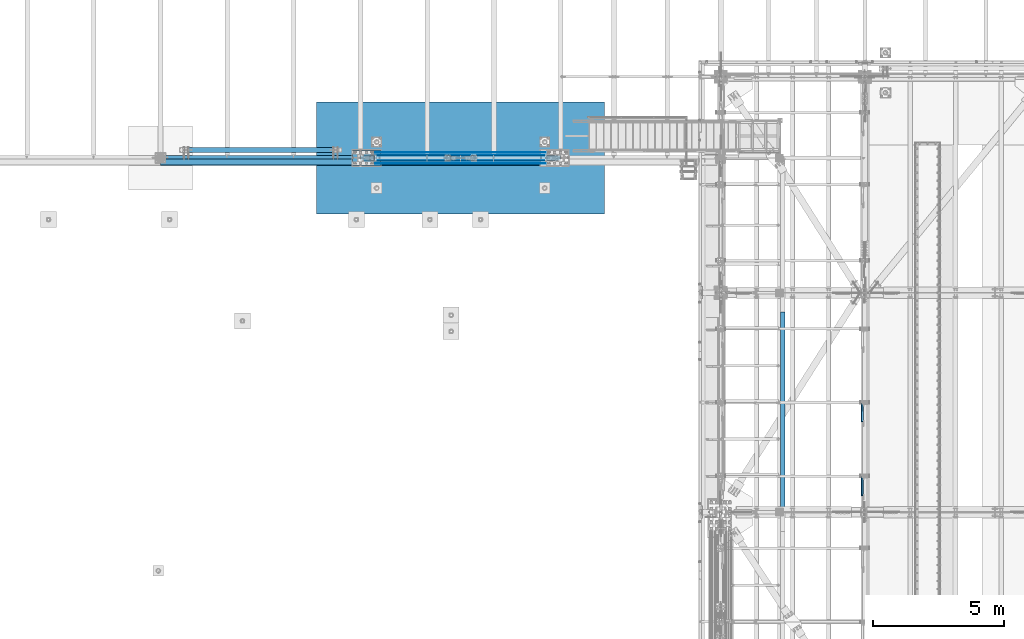
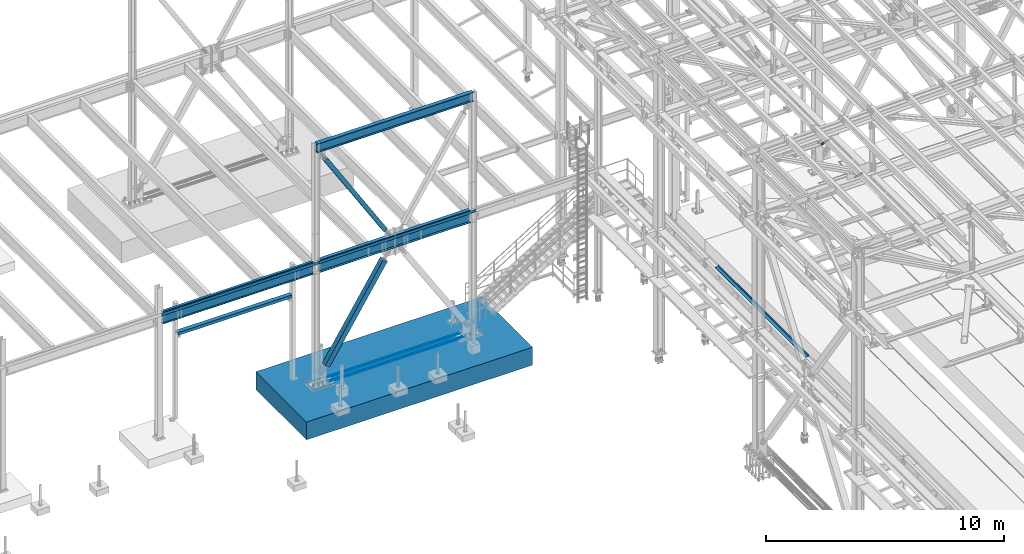
# One storey, part 1875 of 3843: 13 beams, 4 members, 15 elements without a shape of their own.
"""IFC2X3 building model written with IfcOpenShell, lengths in millimetres."""

from ifc_helpers import new_model, si_unit, frame, origin_with_axes, place, context, subcontext, project, spatial, faceted_brep, material, type_object, element, aggregate, save


model = new_model("IFC2X3")

# Units and contexts
model_context = context("Model", 3, precision=1e-05, world=origin_with_axes())
body_context = subcontext(model_context, "Body", "Model", "MODEL_VIEW")
ifc_project = project(units=[si_unit("LENGTHUNIT", "METRE", prefix="MILLI"), si_unit("AREAUNIT", "SQUARE_METRE"), si_unit("VOLUMEUNIT", "CUBIC_METRE"), si_unit("MASSUNIT", "GRAM", prefix="KILO"), si_unit("TIMEUNIT", "SECOND"), si_unit("PLANEANGLEUNIT", "RADIAN"), si_unit("SOLIDANGLEUNIT", "STERADIAN"), si_unit("THERMODYNAMICTEMPERATUREUNIT", "DEGREE_CELSIUS"), si_unit("LUMINOUSINTENSITYUNIT", "LUMEN")], contexts=[model_context])

# Site, building, storey
site_placement = place(None, origin_with_axes())
site = spatial("IfcSite", under=ifc_project, at=site_placement, CompositionType="ELEMENT")
building_placement = place(site_placement, origin_with_axes())
building = spatial("IfcBuilding", under=site, at=building_placement, Name="Undefined", CompositionType="ELEMENT")
storey_placement = place(building_placement, origin_with_axes())
storey = spatial("IfcBuildingStorey", under=building, at=storey_placement, Name="Undefined", CompositionType="ELEMENT", Elevation=0.0)

# Assembly, beam
assembly_1_placement = place(storey_placement, origin_with_axes())
assembly_1 = element("IfcElementAssembly", 1, at=assembly_1_placement, inside=storey, Name="REBAR", AssemblyPlace="NOTDEFINED", PredefinedType="RIGID_FRAME")
ifc_material_1 = material(Name="STEEL/A706-60")
beam_type_1 = type_object("IfcBeamType", Name="#10 REBAR", PredefinedType="NOTDEFINED")
beam_1_placement = place(assembly_1_placement, frame((23418.7999804674, 88912.7, 30132.3375), z_axis=(0.0, 0.0, 1.0), x_axis=(1.0, 0.0, 0.0)))
beam_1 = element("IfcBeam", 2, at=beam_1_placement, type_object=beam_type_1, material=ifc_material_1, Name="REBAR", ObjectType="#10 REBAR", context=body_context, shape_type="Brep", body=[
    faceted_brep([(0.0, -7.9375, 0.0), (0.0, -5.61266007566883, -5.61266007566883), (6502.48749999408, -5.61266007566883, -5.61266007566883), (6502.48749999408, -7.9375, 0.0), (0.0, 0.0, -7.9375), (6502.48749999408, 0.0, -7.9375), (0.0, 5.61266007566883, -5.61266007566883), (6502.48749999408, 5.61266007566883, -5.61266007566883), (0.0, 7.9375, 0.0), (6502.48749999408, 7.9375, 0.0), (0.0, 5.61266007566883, 5.61266007566883), (6502.48749999408, 5.61266007566883, 5.61266007566883), (0.0, 0.0, 7.9375), (6502.48749999408, 0.0, 7.9375), (0.0, -5.61266007566883, 5.61266007566883), (6502.48749999408, -5.61266007566883, 5.61266007566883)], [[[0, 1, 2, 3]], [[1, 4, 5, 2]], [[4, 6, 7, 5]], [[6, 8, 9, 7]], [[8, 10, 11, 9]], [[10, 12, 13, 11]], [[12, 14, 15, 13]], [[14, 0, 3, 15]], [[5, 7, 9, 11, 13, 15, 3, 2]], [[14, 12, 10, 8, 6, 4, 1, 0]]]),
])
aggregate(assembly_1, [beam_1])

assembly_2_placement = place(storey_placement, origin_with_axes())
assembly_2 = element("IfcElementAssembly", 3, at=assembly_2_placement, inside=storey, Name="REBAR", AssemblyPlace="NOTDEFINED", PredefinedType="RIGID_FRAME")
beam_2_placement = place(assembly_2_placement, frame((23418.7999804674, 89014.3, 30132.3375), z_axis=(0.0, 0.0, 1.0), x_axis=(1.0, 0.0, 0.0)))
beam_2 = element("IfcBeam", 4, at=beam_2_placement, type_object=beam_type_1, material=ifc_material_1, Name="REBAR", ObjectType="#10 REBAR", context=body_context, shape_type="Brep", body=[
    faceted_brep([(0.0, -7.9375, 0.0), (0.0, -5.61266007566883, -5.61266007566883), (6502.48749999408, -5.61266007566883, -5.61266007566883), (6502.48749999408, -7.9375, 0.0), (0.0, 0.0, -7.9375), (6502.48749999408, 0.0, -7.9375), (0.0, 5.61266007566883, -5.61266007566883), (6502.48749999408, 5.61266007566883, -5.61266007566883), (0.0, 7.9375, 0.0), (6502.48749999408, 7.9375, 0.0), (0.0, 5.61266007566883, 5.61266007566883), (6502.48749999408, 5.61266007566883, 5.61266007566883), (0.0, 0.0, 7.9375), (6502.48749999408, 0.0, 7.9375), (0.0, -5.61266007566883, 5.61266007566883), (6502.48749999408, -5.61266007566883, 5.61266007566883)], [[[0, 1, 2, 3]], [[1, 4, 5, 2]], [[4, 6, 7, 5]], [[6, 8, 9, 7]], [[8, 10, 11, 9]], [[10, 12, 13, 11]], [[12, 14, 15, 13]], [[14, 0, 3, 15]], [[5, 7, 9, 11, 13, 15, 3, 2]], [[14, 12, 10, 8, 6, 4, 1, 0]]]),
])
aggregate(assembly_2, [beam_2])

assembly_3_placement = place(storey_placement, origin_with_axes())
assembly_3 = element("IfcElementAssembly", 5, at=assembly_3_placement, inside=storey, Name="REBAR", AssemblyPlace="NOTDEFINED", PredefinedType="RIGID_FRAME")
beam_3_placement = place(assembly_3_placement, frame((23418.7999804674, 89217.5, 30132.3375), z_axis=(0.0, 0.0, 1.0), x_axis=(1.0, 0.0, 0.0)))
beam_3 = element("IfcBeam", 6, at=beam_3_placement, type_object=beam_type_1, material=ifc_material_1, Name="REBAR", ObjectType="#10 REBAR", context=body_context, shape_type="Brep", body=[
    faceted_brep([(0.0, -7.9375, 0.0), (0.0, -5.61266007566883, -5.61266007566883), (6502.48749999408, -5.61266007566883, -5.61266007566883), (6502.48749999408, -7.9375, 0.0), (0.0, 0.0, -7.9375), (6502.48749999408, 0.0, -7.9375), (0.0, 5.61266007566883, -5.61266007566883), (6502.48749999408, 5.61266007566883, -5.61266007566883), (0.0, 7.9375, 0.0), (6502.48749999408, 7.9375, 0.0), (0.0, 5.61266007566883, 5.61266007566883), (6502.48749999408, 5.61266007566883, 5.61266007566883), (0.0, 0.0, 7.9375), (6502.48749999408, 0.0, 7.9375), (0.0, -5.61266007566883, 5.61266007566883), (6502.48749999408, -5.61266007566883, 5.61266007566883)], [[[0, 1, 2, 3]], [[1, 4, 5, 2]], [[4, 6, 7, 5]], [[6, 8, 9, 7]], [[8, 10, 11, 9]], [[10, 12, 13, 11]], [[12, 14, 15, 13]], [[14, 0, 3, 15]], [[5, 7, 9, 11, 13, 15, 3, 2]], [[14, 12, 10, 8, 6, 4, 1, 0]]]),
])
aggregate(assembly_3, [beam_3])

assembly_4_placement = place(storey_placement, origin_with_axes())
assembly_4 = element("IfcElementAssembly", 7, at=assembly_4_placement, inside=storey, Name="REBAR", AssemblyPlace="NOTDEFINED", PredefinedType="RIGID_FRAME")
beam_4_placement = place(assembly_4_placement, frame((23418.7999804674, 89319.1, 30132.3375), z_axis=(0.0, 0.0, 1.0), x_axis=(1.0, 0.0, 0.0)))
beam_4 = element("IfcBeam", 8, at=beam_4_placement, type_object=beam_type_1, material=ifc_material_1, Name="REBAR", ObjectType="#10 REBAR", context=body_context, shape_type="Brep", body=[
    faceted_brep([(0.0, -7.9375, 0.0), (0.0, -5.61266007566883, -5.61266007566883), (6502.48749999408, -5.61266007566883, -5.61266007566883), (6502.48749999408, -7.9375, 0.0), (0.0, 0.0, -7.9375), (6502.48749999408, 0.0, -7.9375), (0.0, 5.61266007566883, -5.61266007566883), (6502.48749999408, 5.61266007566883, -5.61266007566883), (0.0, 7.9375, 0.0), (6502.48749999408, 7.9375, 0.0), (0.0, 5.61266007566883, 5.61266007566883), (6502.48749999408, 5.61266007566883, 5.61266007566883), (0.0, 0.0, 7.9375), (6502.48749999408, 0.0, 7.9375), (0.0, -5.61266007566883, 5.61266007566883), (6502.48749999408, -5.61266007566883, 5.61266007566883)], [[[0, 1, 2, 3]], [[1, 4, 5, 2]], [[4, 6, 7, 5]], [[6, 8, 9, 7]], [[8, 10, 11, 9]], [[10, 12, 13, 11]], [[12, 14, 15, 13]], [[14, 0, 3, 15]], [[5, 7, 9, 11, 13, 15, 3, 2]], [[14, 12, 10, 8, 6, 4, 1, 0]]]),
])
aggregate(assembly_4, [beam_4])

assembly_5_placement = place(storey_placement, origin_with_axes())
assembly_5 = element("IfcElementAssembly", 9, at=assembly_5_placement, inside=storey, Name="BEAM", AssemblyPlace="NOTDEFINED", PredefinedType="RIGID_FRAME")
ifc_material_2 = material(Name="STEEL/A36")
beam_type_2 = type_object("IfcBeamType", PredefinedType="NOTDEFINED")
beam_5_placement = place(assembly_5_placement, frame((38858.825, 79441.675, 34039.175), z_axis=(0.0, -1.0, 0.0), x_axis=(1.0, 0.0, 0.0)))
beam_5 = element("IfcBeam", 10, at=beam_5_placement, type_object=beam_type_2, material=ifc_material_2, Name="BENT_PLATE", context=body_context, shape_type="Brep", body=[
    faceted_brep([(0.0, -3.17500000000291, -3810.0), (0.0, -3.17500000000291, 3810.0), (0.0, 3.17500000000291, 3810.0), (0.0, 3.17500000000291, -3810.0), (158.750005722046, 3.17500000000291, 3810.0), (158.750005722046, 3.17500000000291, -3810.0), (165.100006103516, -3.17500000000291, -3810.0), (165.100006103516, -3.17500000000291, 3810.0), (158.749999999993, 98.4249996185172, 3810.0), (158.749999999993, 98.4249996185172, -3810.0), (165.099999999999, 98.4249999999811, 3810.0), (165.099999999999, 98.4249999999811, -3810.0)], [[[0, 1, 2, 3]], [[3, 2, 4, 5]], [[1, 0, 6, 7]], [[5, 4, 8, 9]], [[4, 2, 1, 7, 10, 8]], [[7, 6, 11, 10]], [[6, 0, 3, 5, 9, 11]], [[10, 11, 9, 8]]]),
])
aggregate(assembly_5, [beam_5])

# Assembly, member
assembly_6_placement = place(storey_placement, origin_with_axes())
assembly_6 = element("IfcElementAssembly", 11, at=assembly_6_placement, inside=storey, Name="None", AssemblyPlace="NOTDEFINED", PredefinedType="RIGID_FRAME")
ifc_material_3 = material(Name="STEEL/A992")
member_type_1 = type_object("IfcMemberType", Name="HSS8X8X3/16", PredefinedType="NOTDEFINED")
member_1_placement = place(assembly_6_placement, frame((26220.9589494341, 89115.9000061035, 36853.7019867382), z_axis=(0.0, 1.0, 0.0), x_axis=(-0.529701323009257, 0.0, 0.848184242014813)))
member_1 = element("IfcMember", 12, at=member_1_placement, type_object=member_type_1, material=ifc_material_3, Name="None", ObjectType="HSS8X8X3/16", context=body_context, shape_type="Brep", body=[
    faceted_brep([(2.03726813197136e-10, 96.8375000003298, -96.8374999999942), (-2.18278728425503e-10, -96.837500000317, -96.8374999999942), (5518.14999998289, -96.8375000060396, -96.8374999999942), (5518.14999998332, 96.8374999946072, -96.8374999999942), (-2.18278728425503e-10, -96.837500000317, 96.8374999999942), (5518.14999998289, -96.8375000060396, 96.8374999999942), (2.03726813197136e-10, 96.8375000003298, 96.8374999999942), (5518.14999998332, 96.8374999946072, 96.8374999999942), (2.18278728425503e-10, 101.600000000345, -101.600000000006), (2.18278728425503e-10, 101.600000000345, 101.600000000006), (5518.14999998333, 101.599999994626, 101.600000000006), (5518.14999998333, 101.599999994626, -101.600000000006), (-2.25554686039686e-10, -101.600000000329, 101.600000000006), (5518.14999998289, -101.600000006059, 101.600000000006), (-2.25554686039686e-10, -101.600000000329, -101.600000000006), (5518.14999998289, -101.600000006059, -101.600000000006)], [[[0, 1, 2, 3]], [[1, 4, 5, 2]], [[4, 6, 7, 5]], [[6, 0, 3, 7]], [[8, 9, 10, 11]], [[9, 12, 13, 10]], [[12, 14, 15, 13]], [[14, 8, 11, 15]], [[13, 15, 11, 10], [5, 7, 3, 2]], [[14, 12, 9, 8], [6, 4, 1, 0]]]),
])
aggregate(assembly_6, [member_1])

# Assembly, beam
assembly_7_placement = place(storey_placement, origin_with_axes())
assembly_7 = element("IfcElementAssembly", 13, at=assembly_7_placement, inside=storey, Name="BEAM", AssemblyPlace="NOTDEFINED", PredefinedType="RIGID_FRAME")
beam_type_3 = type_object("IfcBeamType", Name="W18X65", PredefinedType="NOTDEFINED")
beam_6_placement = place(assembly_7_placement, frame((22860.0, 89115.9, 42235.4375), z_axis=(0.0, 0.0, 1.0), x_axis=(1.0, 0.0, 0.0)))
beam_6 = element("IfcBeam", 14, at=beam_6_placement, type_object=beam_type_3, material=ifc_material_3, Name="BEAM", ObjectType="W18X65", context=body_context, shape_type="Brep", body=[
    faceted_brep([(0.0, 96.8374999999942, -233.362500000003), (0.0, 96.8374999999942, -214.3125), (7620.0, 96.8374999999942, -214.3125), (7620.0, 96.8374999999942, -233.362500000003), (0.0, 5.55624999999418, -214.3125), (7620.0, 5.55624999999418, -214.3125), (0.0, 5.55624999999418, 214.3125), (7620.0, 5.55624999999418, 214.3125), (0.0, 96.8374999999942, 214.3125), (7620.0, 96.8374999999942, 214.3125), (0.0, 96.8374999999942, 233.362500000003), (7620.0, 96.8374999999942, 233.362500000003), (0.0, -96.8374999999942, 233.362500000003), (7620.0, -96.8374999999942, 233.362500000003), (0.0, -96.8374999999942, 214.3125), (7620.0, -96.8374999999942, 214.3125), (0.0, -5.55624999999418, 214.3125), (7620.0, -5.55624999999418, 214.3125), (0.0, -5.55624999999418, -214.3125), (7620.0, -5.55624999999418, -214.3125), (0.0, -96.8374999999942, -214.3125), (7620.0, -96.8374999999942, -214.3125), (0.0, -96.8374999999942, -233.362500000003), (7620.0, -96.8374999999942, -233.362500000003)], [[[0, 1, 2, 3]], [[1, 4, 5, 2]], [[4, 6, 7, 5]], [[6, 8, 9, 7]], [[8, 10, 11, 9]], [[10, 12, 13, 11]], [[12, 14, 15, 13]], [[14, 16, 17, 15]], [[16, 18, 19, 17]], [[18, 20, 21, 19]], [[20, 22, 23, 21]], [[22, 0, 3, 23]], [[5, 7, 9, 11, 13, 15, 17, 19, 21, 23, 3, 2]], [[22, 20, 18, 16, 14, 12, 10, 8, 6, 4, 1, 0]]]),
])
aggregate(assembly_7, [beam_6])

# Assembly, member
assembly_8_placement = place(storey_placement, origin_with_axes())
assembly_8 = element("IfcElementAssembly", 15, at=assembly_8_placement, inside=storey, Name="ANGLE", AssemblyPlace="NOTDEFINED", PredefinedType="RIGID_FRAME")
ifc_material_4 = material(Name="STEEL/A572-50")
member_type_2 = type_object("IfcMemberType", Name="L3X3X1/4", PredefinedType="NOTDEFINED")
member_2_placement = place(assembly_8_placement, frame((41973.5, 75994.4404633525, 42306.0595366268), z_axis=(0.0, -0.707106781186548, -0.707106781186548), x_axis=(5.70000238222118e-08, 0.707106781186546, -0.707106781186546)))
member_2 = element("IfcMember", 16, at=member_2_placement, type_object=member_type_2, material=ifc_material_4, Name="ANGLE", ObjectType="L3X3X1/4", context=body_context, shape_type="Brep", body=[
    faceted_brep([(1339.21607517403, -38.0999999999985, -31.7500000069995), (1339.21607517409, -38.0999999999985, -38.1000000070053), (1339.21607517409, 38.0999999999985, -38.1000000070053), (1339.21607517331, 38.0999999999985, 38.0999999932101), (1339.21607517331, 31.75, 38.0999999932101), (1339.21607517403, 31.75, -31.7500000069995), (348.616075173355, 31.75, 38.0999999983032), (348.616075174075, 31.75, -31.7500000019063), (348.616075174075, -38.0999999999985, -31.7500000019063), (348.616075174134, -38.0999999999985, -38.1000000019121), (348.616075174134, 38.0999999999985, -38.1000000019121), (348.616075173355, 38.0999999999985, 38.0999999983032)], [[[0, 1, 2, 3, 4, 5]], [[5, 4, 6, 7]], [[0, 5, 7, 8]], [[1, 0, 8, 9]], [[2, 1, 9, 10]], [[3, 2, 10, 11]], [[4, 3, 11, 6]], [[10, 9, 8, 7, 6, 11]]]),
])
aggregate(assembly_8, [member_2])

assembly_9_placement = place(storey_placement, origin_with_axes())
assembly_9 = element("IfcElementAssembly", 17, at=assembly_9_placement, inside=storey, Name="ANGLE", AssemblyPlace="NOTDEFINED", PredefinedType="RIGID_FRAME")
member_3_placement = place(assembly_9_placement, frame((41973.5, 78809.0443412462, 42298.1556586944), z_axis=(0.0, -0.707106781186548, -0.707106781186548), x_axis=(5.70000238222118e-08, 0.707106781186546, -0.707106781186546)))
member_3 = element("IfcMember", 18, at=member_3_placement, type_object=member_type_2, material=ifc_material_4, Name="ANGLE", ObjectType="L3X3X1/4", context=body_context, shape_type="Brep", body=[
    faceted_brep([(1328.03830384177, -38.0999999999985, -31.7500000069267), (1328.03830384184, -38.0999999999985, -38.1000000069471), (1328.03830384184, 38.0999999999985, -38.1000000069471), (1328.03830384104, 38.0999999999985, 38.0999999932683), (1328.03830384104, 31.75, 38.0999999932683), (1328.03830384177, 31.75, -31.7500000069267), (337.438303841023, 31.75, 38.0999999983615), (337.438303841747, 31.75, -31.7500000018335), (337.438303841747, -38.0999999999985, -31.7500000018335), (337.438303841802, -38.0999999999985, -38.1000000018394), (337.438303841802, 38.0999999999985, -38.1000000018394), (337.438303841023, 38.0999999999985, 38.0999999983615)], [[[0, 1, 2, 3, 4, 5]], [[5, 4, 6, 7]], [[0, 5, 7, 8]], [[1, 0, 8, 9]], [[2, 1, 9, 10]], [[3, 2, 10, 11]], [[4, 3, 11, 6]], [[10, 9, 8, 7, 6, 11]]]),
])
aggregate(assembly_9, [member_3])

assembly_10_placement = place(storey_placement, origin_with_axes())
assembly_10 = element("IfcElementAssembly", 19, at=assembly_10_placement, inside=storey, Name="None", AssemblyPlace="NOTDEFINED", PredefinedType="RIGID_FRAME")
member_type_3 = type_object("IfcMemberType", Name="HSS10X10X1/4", PredefinedType="NOTDEFINED")
member_4_placement = place(assembly_10_placement, frame((23352.9716849559, 89115.9000061035, 30902.0628320385), z_axis=(0.0, -1.0, 0.0), x_axis=(0.535402318785024, 0.0, 0.844597156660866)))
member_4 = element("IfcMember", 20, at=member_4_placement, type_object=member_type_3, material=ifc_material_3, Name="None", ObjectType="HSS10X10X1/4", context=body_context, shape_type="Brep", body=[
    faceted_brep([(2.00088834390044e-10, 120.650000000089, -120.649999999994), (-2.03726813197136e-10, -120.650000000081, -120.649999999994), (5264.15000005166, -120.650000008987, -120.649999999994), (5264.15000005206, 120.649999991176, -120.649999999994), (-2.03726813197136e-10, -120.650000000081, 120.649999999994), (5264.15000005166, -120.650000008987, 120.649999999994), (2.00088834390044e-10, 120.650000000089, 120.649999999994), (5264.15000005206, 120.649999991176, 120.649999999994), (2.16459739021957e-10, 127.000000000087, -127.0), (2.16459739021957e-10, 127.000000000087, 127.0), (5264.15000005208, 126.999999991182, 127.0), (5264.15000005208, 126.999999991182, -127.0), (-2.14640749618411e-10, -127.00000000008, 127.0), (5264.15000005164, -127.000000008993, 127.0), (-2.14640749618411e-10, -127.00000000008, -127.0), (5264.15000005164, -127.000000008993, -127.0)], [[[0, 1, 2, 3]], [[1, 4, 5, 2]], [[4, 6, 7, 5]], [[6, 0, 3, 7]], [[8, 9, 10, 11]], [[9, 12, 13, 10]], [[12, 14, 15, 13]], [[14, 8, 11, 15]], [[13, 15, 11, 10], [5, 7, 3, 2]], [[14, 12, 9, 8], [6, 4, 1, 0]]]),
])
aggregate(assembly_10, [member_4])

# Assembly, beam
assembly_11_placement = place(storey_placement, origin_with_axes())
assembly_11 = element("IfcElementAssembly", 21, at=assembly_11_placement, inside=storey, Name="BEAM", AssemblyPlace="NOTDEFINED", PredefinedType="RIGID_FRAME")
beam_type_4 = type_object("IfcBeamType", PredefinedType="NOTDEFINED")
beam_7_placement = place(assembly_11_placement, frame((26670.0, 89052.4, 36439.475), z_axis=(-1.0, 0.0, 0.0), x_axis=(0.0, -1.0, 0.0)))
beam_7 = element("IfcBeam", 22, at=beam_7_placement, type_object=beam_type_4, material=ifc_material_2, Name="BENT_PLATE", context=body_context, shape_type="Brep", body=[
    faceted_brep([(57.1500000000087, -3.17500000000291, -19.0499999999956), (57.1500000000087, 3.17500000000291, -19.0499999999956), (0.0, 3.17500000000291, -19.0499999999956), (0.0, -3.17500000000291, -19.0499999999956), (57.1500015258789, -3.17499999999927, 19.0499992370605), (57.1500015258789, 3.17499999999927, 19.0499992370605), (4.36557456851006e-11, -3.17499999998836, 19.0499992370969), (1.45519152283669e-11, 3.17499999998836, 19.0499992370824), (76.2000122051686, -3.17500000000291, 3635.37499999908), (76.2000122051686, 3.17500000000291, 3635.37499999908), (0.0, 3.17500000000291, 3635.375), (0.0, -3.17500000000291, 3635.375), (76.2000122074387, -3.17500000000291, 3806.82499999925), (76.2000122074387, 3.17500000000291, 3806.825), (215.899993896481, -3.17500000000291, 3806.825), (215.899993896481, 136.524996948239, 3806.825), (209.549993896482, 136.524996948239, 3806.825), (209.549993896482, 3.17500000000291, 3806.825), (209.549993896482, 3.17500000000291, -3806.825), (209.549993896482, 136.524996948239, -3806.825), (215.899993896481, 136.524996948239, -3806.825), (215.899993896481, -3.17500000000291, -3806.825), (77.7874969481345, -3.17499999999563, -3806.825), (77.7874969481345, 3.17500000000291, -3806.825), (77.7874969481491, -3.17499999999563, -3636.96249389547), (77.7874969481491, 3.17500000000291, -3636.96249389547), (0.0, -3.17500000000291, -3636.96249389547), (0.0, 3.17500000000291, -3636.96249389547)], [[[0, 1, 2, 3]], [[4, 5, 1, 0]], [[6, 7, 5, 4]], [[8, 9, 10, 11]], [[12, 13, 9, 8]], [[14, 15, 16, 17, 13, 12]], [[18, 17, 16, 19]], [[15, 20, 19, 16]], [[14, 21, 20, 15]], [[18, 19, 20, 21, 22, 23]], [[24, 25, 23, 22]], [[26, 27, 25, 24]], [[27, 26, 3, 2]], [[10, 9, 13, 17, 18, 23, 25, 27, 2, 1, 5, 7]], [[11, 10, 7, 6]], [[3, 26, 24, 22, 21, 14, 12, 8, 11, 6, 4, 0]]]),
])

assembly_12_placement = place(storey_placement, origin_with_axes())
assembly_12 = element("IfcElementAssembly", 23, at=assembly_12_placement, inside=storey, Name="BEAM", AssemblyPlace="NOTDEFINED", PredefinedType="RIGID_FRAME")
beam_type_5 = type_object("IfcBeamType", PredefinedType="NOTDEFINED")
beam_8_placement = place(assembly_12_placement, frame((19050.0, 89077.8, 36439.475), z_axis=(-1.0, 0.0, 0.0), x_axis=(0.0, -1.0, 0.0)))
beam_8 = element("IfcBeam", 24, at=beam_8_placement, type_object=beam_type_5, material=ifc_material_2, Name="BENT_PLATE", context=body_context, shape_type="Brep", body=[
    faceted_brep([(101.599996948149, -3.17499999999563, 3670.30000000001), (101.599996948149, 3.17500000000291, 3670.30000000001), (0.0, 3.17500000000291, 3670.30000000001), (0.0, -3.17500000000291, 3670.30000000001), (101.599996948149, -3.17499999999563, 3806.825), (101.599996948149, 3.17500000000291, 3806.825), (0.0, -3.17500000000291, -3667.12500305074), (0.0, 3.17500000000291, -3667.12500305074), (101.600012207025, 3.17500000000291, -3667.125), (101.600012207025, -3.17500000000291, -3667.125), (101.600012207025, 3.17500000000291, -3806.825), (101.600012207025, -3.17500000000291, -3806.825), (234.950003051752, 3.17500000000291, -3806.825), (234.950003051752, 136.524996948247, -3806.825), (241.300003051758, 136.524996948247, -3806.825), (241.300003051758, -3.17500000000291, -3806.825), (234.950003051752, 3.17500000000291, 3806.825), (234.950003051752, 136.524996948247, 3806.825), (241.300003051758, 136.524996948247, 3806.825), (241.300003051758, -3.17500000000291, 3806.825)], [[[0, 1, 2, 3]], [[4, 5, 1, 0]], [[6, 7, 8, 9]], [[9, 8, 10, 11]], [[12, 13, 14, 15, 11, 10]], [[12, 16, 17, 13]], [[18, 14, 13, 17]], [[19, 15, 14, 18]], [[3, 6, 9, 11, 15, 19, 4, 0]], [[7, 6, 3, 2]], [[16, 12, 10, 8, 7, 2, 1, 5]], [[19, 18, 17, 16, 5, 4]]]),
])

assembly_13_placement = place(storey_placement, origin_with_axes())
assembly_13 = element("IfcElementAssembly", 25, at=assembly_13_placement, inside=storey, Name="BEAM", AssemblyPlace="NOTDEFINED", PredefinedType="RIGID_FRAME")
ifc_material_5 = material()
beam_type_6 = type_object("IfcBeamType", Name="HSS8X6X1/2", PredefinedType="NOTDEFINED")
beam_9_placement = place(assembly_13_placement, frame((16217.9, 89420.7, 34836.1), z_axis=(0.0, 1.0, 0.0), x_axis=(1.0, 0.0, 0.0)))
beam_9 = element("IfcBeam", 26, at=beam_9_placement, type_object=beam_type_6, material=ifc_material_5, Name="BEAM", ObjectType="HSS8X6X1/2", context=body_context, shape_type="Brep", body=[
    faceted_brep([(76.1999999999989, 63.5, -88.8999999999942), (76.1999999999989, -63.5, -88.8999999999942), (5613.4, -63.5, -88.8999999999942), (5613.4, 63.5, -88.8999999999942), (76.1999999999989, -63.5, 88.8999999999942), (5613.4, -63.5, 88.8999999999942), (76.1999999999989, 63.5, 88.8999999999942), (5613.4, 63.5, 88.8999999999942), (76.1999999999989, 76.1999999999971, -101.600000000006), (76.1999999999989, 76.1999999999971, 101.600000000006), (5613.4, 76.1999999999971, 101.600000000006), (5613.4, 76.1999999999971, -101.600000000006), (76.1999999999989, -76.1999999999971, 101.600000000006), (5613.4, -76.1999999999971, 101.600000000006), (76.1999999999989, -76.1999999999971, -101.600000000006), (5613.4, -76.1999999999971, -101.600000000006)], [[[0, 1, 2, 3]], [[1, 4, 5, 2]], [[4, 6, 7, 5]], [[6, 0, 3, 7]], [[8, 9, 10, 11]], [[9, 12, 13, 10]], [[12, 14, 15, 13]], [[14, 8, 11, 15]], [[13, 15, 11, 10], [5, 7, 3, 2]], [[14, 12, 9, 8], [6, 4, 1, 0]]]),
])
aggregate(assembly_13, [beam_9])

# Beam
beam_type_7 = type_object("IfcBeamType", Name="W24X68", PredefinedType="NOTDEFINED")
beam_10_placement = place(assembly_11_placement, frame((22860.0, 89115.9, 36134.675), z_axis=(0.0, 0.0, 1.0), x_axis=(1.0, 0.0, 0.0)))
beam_10 = element("IfcBeam", 27, at=beam_10_placement, type_object=beam_type_7, material=ifc_material_3, Name="BEAM", ObjectType="W24X68", context=body_context, shape_type="Brep", body=[
    faceted_brep([(146.115804864854, -5.55624999999418, 258.762499999997), (139.700000000001, 5.55624999999418, 258.762499999997), (139.700000000001, 5.55624999999418, -258.762499999997), (146.115804864854, -5.55624999999418, -258.762499999997), (195.152324331713, -5.55624999999418, -258.762499999997), (195.152324331713, 5.55624999999418, -258.762499999997), (200.316860659659, 5.55624999999418, -260.284176418114), (200.316860659659, -5.55624999999418, -260.284176418114), (203.831265028453, 5.55624999999418, -264.363011611735), (203.831265028453, -5.55624999999418, -264.363011611735), (204.572642642106, 5.55624999999418, -269.69576829455), (204.572642642106, -5.55624999999418, -269.69576829455), (202.304114366383, 5.55624999999418, -274.578566064927), (202.304114366383, -5.55624999999418, -274.578566064927), (197.750502483541, 5.55624999999418, -277.451291847967), (197.750502483541, -5.55624999999418, -277.451291847967), (164.281999999999, 5.55624999999418, -286.940499999997), (164.281999999999, -5.55624999999418, -286.940499999997), (148.177810053228, 5.55624999999418, -286.940499999997), (148.177810053228, -5.55624999999418, -286.940499999997), (7472.05137989355, 5.55624999999418, -287.337500000001), (7472.05137989355, 114.300000000003, -287.337500000001), (147.948620106454, 114.300000000003, -287.337500000001), (147.948620106454, 5.55624999999418, -287.337500000001), (7480.3, 114.300000000003, -301.625), (139.699999999997, 114.3, -301.625), (7480.3, -114.300000000003, -301.625), (139.699999999997, -114.3, -301.625), (7472.05137989355, -114.300000000003, -287.337500000001), (147.948620106454, -114.300000000003, -287.337500000001), (147.948620106454, -5.55624999999418, -287.337500000001), (7472.05137989355, -5.55624999999418, -287.337500000001), (7471.82218994677, 5.55624999999418, -286.940499999997), (7471.82218994677, -5.55624999999418, -286.940499999997), (7455.718, 5.55624999999418, -286.940499999997), (7455.718, -5.55624999999418, -286.940499999997), (7422.24949751646, 5.55624999999418, -277.451291847967), (7422.24949751646, -5.55624999999418, -277.451291847967), (7417.69588563362, 5.55624999999418, -274.578566064927), (7417.69588563362, -5.55624999999418, -274.578566064927), (7415.42735735789, 5.55624999999418, -269.69576829455), (7415.42735735789, -5.55624999999418, -269.69576829455), (7416.16873497155, 5.55624999999418, -264.363011611735), (7416.16873497155, -5.55624999999418, -264.363011611735), (7419.68313934034, 5.55624999999418, -260.284176418114), (7419.68313934034, -5.55624999999418, -260.284176418114), (7424.84767566829, 5.55624999999418, -258.762499999997), (7424.84767566829, -5.55624999999418, -258.762499999997), (7480.3, 5.55624999999418, -258.762499999997), (7473.88419513515, -5.55624999999418, -258.762499999997), (7480.29999999997, 5.55625000000873, 258.762499999997), (7473.88419513515, -5.55624999999418, 258.762499999997), (7424.02967566829, 5.55624999999418, 258.762499999997), (7424.02967566829, -5.55624999999418, 258.762499999997), (7418.86513934034, 5.55624999999418, 260.284176418114), (7418.86513934034, -5.55624999999418, 260.284176418114), (7415.35073497154, 5.55624999999418, 264.363011611735), (7415.35073497154, -5.55624999999418, 264.363011611735), (7414.60935735789, 5.55624999999418, 269.69576829455), (7414.60935735789, -5.55624999999418, 269.69576829455), (7416.87788563361, 5.55624999999418, 274.578566064927), (7416.87788563361, -5.55624999999418, 274.578566064927), (7421.43149751646, 5.55624999999418, 277.451291847967), (7421.43149751646, -5.55624999999418, 277.451291847967), (7454.9, 5.55624999999418, 286.940499999997), (7454.9, -5.55624999999418, 286.940499999997), (7480.3, 5.55624999999418, 286.940499999997), (7480.3, -5.55624999999418, 286.940499999997), (7480.3, 5.55624999999418, 287.337500000001), (7480.3, -5.55624999999418, 287.337500000001), (7480.3, -114.300000000003, 287.337500000001), (7480.3, 114.300000000003, 287.337500000001), (7472.05140070513, 114.300000000003, 301.625), (7472.05140070513, -114.300000000003, 301.625), (139.699999999997, 5.55625, 287.337500000001), (139.699999999997, 114.3, 287.337500000001), (147.948599294868, 114.300000000003, 301.625), (147.948599294868, -114.300000000003, 301.625), (139.699999999997, -114.3, 287.337500000001), (139.699999999997, -5.55625, 287.337500000001), (139.700000000001, 5.55624999999418, 286.940499999997), (139.700000000001, -5.55624999999418, 286.940499999997), (165.100000000002, 5.55624999999418, 286.940499999997), (165.100000000002, -5.55624999999418, 286.940499999997), (198.56850248354, 5.55624999999418, 277.451291847967), (198.56850248354, -5.55624999999418, 277.451291847967), (203.122114366386, 5.55624999999418, 274.578566064927), (203.122114366386, -5.55624999999418, 274.578566064927), (205.390642642109, 5.55624999999418, 269.69576829455), (205.390642642109, -5.55624999999418, 269.69576829455), (204.649265028456, 5.55624999999418, 264.363011611735), (204.649265028456, -5.55624999999418, 264.363011611735), (201.134860659662, 5.55624999999418, 260.284176418114), (201.134860659662, -5.55624999999418, 260.284176418114), (195.970324331713, 5.55624999999418, 258.762499999997), (195.970324331713, -5.55624999999418, 258.762499999997)], [[[0, 1, 2, 3]], [[4, 5, 6, 7]], [[7, 6, 8, 9]], [[9, 8, 10, 11]], [[11, 10, 12, 13]], [[13, 12, 14, 15]], [[15, 14, 16, 17]], [[17, 16, 18, 19]], [[20, 21, 22, 23]], [[21, 24, 25, 22]], [[24, 26, 27, 25]], [[26, 28, 29, 27]], [[19, 18, 23, 22, 25, 27, 29, 30]], [[28, 31, 30, 29]], [[26, 24, 21, 20, 32, 33, 31, 28]], [[34, 35, 33, 32]], [[35, 34, 36, 37]], [[37, 36, 38, 39]], [[39, 38, 40, 41]], [[41, 40, 42, 43]], [[43, 42, 44, 45]], [[45, 44, 46, 47]], [[47, 46, 48, 49]], [[50, 51, 49, 48]], [[52, 53, 51, 50]], [[53, 52, 54, 55]], [[55, 54, 56, 57]], [[57, 56, 58, 59]], [[59, 58, 60, 61]], [[61, 60, 62, 63]], [[63, 62, 64, 65]], [[65, 64, 66, 67]], [[67, 66, 68, 69]], [[70, 69, 68, 71, 72, 73]], [[71, 68, 74, 75]], [[72, 71, 75, 76]], [[73, 72, 76, 77]], [[70, 73, 77, 78]], [[69, 70, 78, 79]], [[77, 76, 75, 74, 79, 78]], [[80, 81, 79, 74]], [[82, 83, 81, 80]], [[83, 82, 84, 85]], [[85, 84, 86, 87]], [[87, 86, 88, 89]], [[89, 88, 90, 91]], [[91, 90, 92, 93]], [[93, 92, 94, 95]], [[4, 7, 9, 11, 13, 15, 17, 19, 30, 31, 33, 35, 37, 39, 41, 43, 45, 47, 49, 51, 53, 55, 57, 59, 61, 63, 65, 67, 69, 79, 81, 83, 85, 87, 89, 91, 93, 95, 0, 3]], [[5, 4, 3, 2]], [[94, 92, 90, 88, 86, 84, 82, 80, 74, 68, 66, 64, 62, 60, 58, 56, 54, 52, 50, 48, 46, 44, 42, 40, 38, 36, 34, 32, 20, 23, 18, 16, 14, 12, 10, 8, 6, 5, 2, 1]], [[95, 94, 1, 0]]]),
])

aggregate(assembly_11, [beam_7, beam_10])

beam_type_8 = type_object("IfcBeamType", Name="W24X55", PredefinedType="NOTDEFINED")
beam_11_placement = place(assembly_12_placement, frame((15240.0, 89115.9, 36136.2625), z_axis=(0.0, 0.0, 1.0), x_axis=(1.0, 0.0, 0.0)))
beam_11 = element("IfcBeam", 28, at=beam_11_placement, type_object=beam_type_8, material=ifc_material_3, Name="BEAM", ObjectType="W24X55", context=body_context, shape_type="Brep", body=[
    faceted_brep([(139.699999999997, -88.8999999999996, -300.037499999999), (139.699999999997, 88.8999999999996, -300.037499999999), (7477.125, 88.8999999999942, -300.037499999999), (7477.125, -88.8999999999942, -300.037499999999), (139.699999999997, -88.8999999999996, -287.337500000001), (139.699999999997, -4.76250000000073, -287.337500000001), (139.699999999997, -4.76250000000073, 287.337500000001), (139.699999999997, -88.8999999999996, 287.337500000001), (139.699999999997, -88.8999999999996, 300.037499999999), (139.699999999997, 88.8999999999996, 300.037499999999), (139.699999999997, 88.8999999999996, 287.337500000001), (139.699999999997, 4.76250000000073, 287.337500000001), (139.7, 4.76249999999709, 262.677499999998), (139.7, 4.76249999999709, -208.702493896482), (139.699999999997, 4.76250000000073, -287.337500000001), (139.699999999997, 88.8999999999996, -287.337500000001), (7477.125, -88.8999999999942, -287.337500000001), (7477.125, -4.76249999999709, -287.337500000001), (7477.125, -4.76249999999709, 287.337500000001), (7477.125, -88.8999999999942, 287.337500000001), (7477.125, -88.8999999999942, 300.037499999999), (7477.125, 88.8999999999942, 300.037499999999), (7477.125, 88.8999999999942, 287.337500000001), (7477.125, 4.76249999999709, 287.337500000001), (7477.125, 4.76249999999709, -287.337500000001), (7477.125, 88.8999999999942, -287.337500000001)], [[[0, 1, 2, 3]], [[0, 4, 5, 6, 7, 8, 9, 10, 11, 12, 13, 14, 15, 1]], [[5, 4, 16, 17]], [[6, 5, 17, 18]], [[7, 6, 18, 19]], [[8, 7, 19, 20]], [[9, 8, 20, 21]], [[10, 9, 21, 22]], [[11, 10, 22, 23]], [[14, 13, 12, 11, 23, 24]], [[15, 14, 24, 25]], [[1, 15, 25, 2]], [[24, 23, 22, 21, 20, 19, 18, 17, 16, 3, 2, 25]], [[4, 0, 3, 16]]]),
])

aggregate(assembly_12, [beam_8, beam_11])

# Assembly, beam
assembly_14_placement = place(storey_placement, origin_with_axes())
assembly_14 = element("IfcElementAssembly", 29, at=assembly_14_placement, inside=storey, Name="BEAM", AssemblyPlace="NOTDEFINED", PredefinedType="REINFORCEMENT_UNIT")
ifc_material_6 = material(Name="CONCRETE/5000")
beam_type_9 = type_object("IfcBeamType", PredefinedType="NOTDEFINED")
beam_12_placement = place(assembly_14_placement, frame((21183.6, 89115.9, 29565.6), z_axis=(0.0, 0.0, 1.0), x_axis=(1.0, 0.0, 0.0)))
beam_12 = element("IfcBeam", 30, at=beam_12_placement, type_object=beam_type_9, material=ifc_material_6, Name="BEAM", context=body_context, shape_type="Brep", body=[
    faceted_brep([(0.0, 2133.60000000001, -457.200000000001), (0.0, 2133.60000000001, 457.200000000001), (10972.8, 2133.60000000001, 457.200000000001), (10972.8, 2133.60000000001, -457.200000000001), (0.0, -2133.60000000001, 457.200000000001), (10972.8, -2133.60000000001, 457.200000000001), (0.0, -2133.60000000001, -457.200000000001), (10972.8, -2133.60000000001, -457.200000000001)], [[[0, 1, 2, 3]], [[1, 4, 5, 2]], [[4, 6, 7, 5]], [[6, 0, 3, 7]], [[5, 7, 3, 2]], [[6, 4, 1, 0]]]),
])
aggregate(assembly_14, [beam_12])

assembly_15_placement = place(storey_placement, origin_with_axes())
assembly_15 = element("IfcElementAssembly", 31, at=assembly_15_placement, inside=storey, Name="TEMPLATE", AssemblyPlace="NOTDEFINED", PredefinedType="RIGID_FRAME")
beam_type_10 = type_object("IfcBeamType", PredefinedType="NOTDEFINED")
beam_13_placement = place(assembly_15_placement, frame((23622.0000061035, 89115.9, 30065.6625), z_axis=(0.0, -1.0, 0.0), x_axis=(-1.0, 0.0, 0.0)))
beam_13 = element("IfcBeam", 32, at=beam_13_placement, type_object=beam_type_10, material=ifc_material_4, Name="TEMPLATE", context=body_context, shape_type="Brep", body=[
    faceted_brep([(0.0, 4.76250000000073, -304.800000000003), (0.0, 4.76250000000073, 304.800000000003), (1066.80001220703, 4.76250000000073, 304.800000000003), (1066.80001220703, 4.76250000000073, -304.800000000003), (0.0, -4.76250000000073, 304.800000000003), (1066.80001220703, -4.76250000000073, 304.800000000003), (0.0, -4.76250000000073, -304.800000000003), (1066.80001220703, -4.76250000000073, -304.800000000003)], [[[0, 1, 2, 3]], [[1, 4, 5, 2]], [[4, 6, 7, 5]], [[6, 0, 3, 7]], [[5, 7, 3, 2]], [[6, 4, 1, 0]]]),
])
aggregate(assembly_15, [beam_13])

save(model, "model.ifc")
